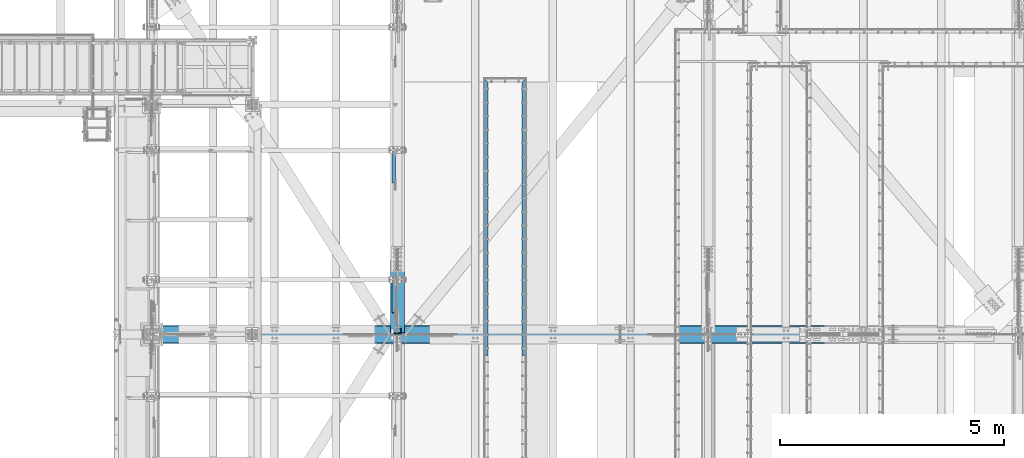
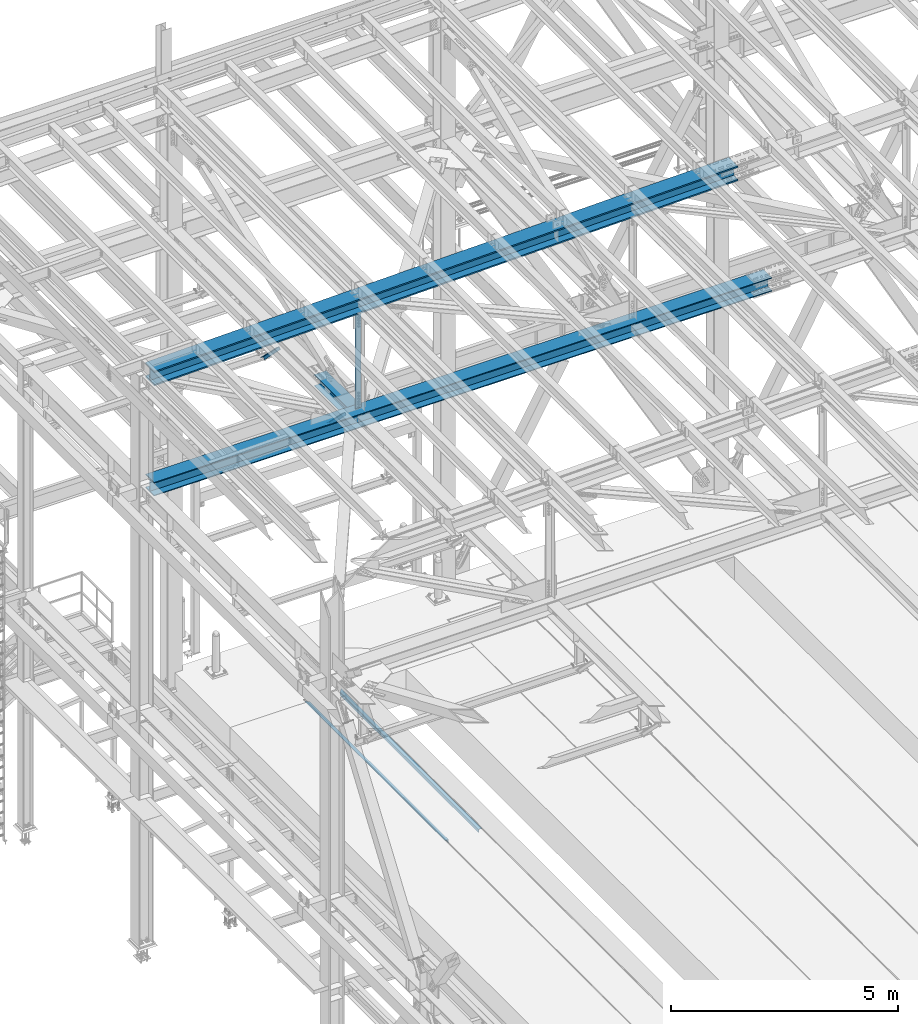
# One storey, part 1880 of 3843: 6 beams, 2 members, 7 elements without a shape of their own.
"""IFC2X3 building model written with IfcOpenShell, lengths in millimetres."""

from ifc_helpers import new_model, si_unit, frame, origin_with_axes, place, context, subcontext, project, spatial, faceted_brep, material, type_object, element, aggregate, save


model = new_model("IFC2X3")

# Units and contexts
model_context = context("Model", 3, precision=1e-05, world=origin_with_axes())
body_context = subcontext(model_context, "Body", "Model", "MODEL_VIEW")
ifc_project = project(units=[si_unit("LENGTHUNIT", "METRE", prefix="MILLI"), si_unit("AREAUNIT", "SQUARE_METRE"), si_unit("VOLUMEUNIT", "CUBIC_METRE"), si_unit("MASSUNIT", "GRAM", prefix="KILO"), si_unit("TIMEUNIT", "SECOND"), si_unit("PLANEANGLEUNIT", "RADIAN"), si_unit("SOLIDANGLEUNIT", "STERADIAN"), si_unit("THERMODYNAMICTEMPERATUREUNIT", "DEGREE_CELSIUS"), si_unit("LUMINOUSINTENSITYUNIT", "LUMEN")], contexts=[model_context])

# Site, building, storey
site_placement = place(None, origin_with_axes())
site = spatial("IfcSite", under=ifc_project, at=site_placement, CompositionType="ELEMENT")
building_placement = place(site_placement, origin_with_axes())
building = spatial("IfcBuilding", under=site, at=building_placement, Name="Undefined", CompositionType="ELEMENT")
storey_placement = place(building_placement, origin_with_axes())
storey = spatial("IfcBuildingStorey", under=building, at=storey_placement, Name="Undefined", CompositionType="ELEMENT", Elevation=0.0)

# Assembly, beam
assembly_1_placement = place(storey_placement, origin_with_axes())
assembly_1 = element("IfcElementAssembly", 1, at=assembly_1_placement, inside=storey, Name="EMBED_ANGLE", AssemblyPlace="NOTDEFINED", PredefinedType="RIGID_FRAME")
ifc_material_1 = material(Name="STEEL/A36")
beam_type_1 = type_object("IfcBeamType", Name="L3-1/2X3-1/2X5/16", PredefinedType="NOTDEFINED")
beam_1_placement = place(assembly_1_placement, frame((44887.896, 89703.275, 30419.675), z_axis=(0.0, 0.0, -1.0), x_axis=(0.0, -1.0, 0.0)))
beam_1 = element("IfcBeam", 2, at=beam_1_placement, type_object=beam_type_1, material=ifc_material_1, Name="EMBED_ANGLE", ObjectType="L3-1/2X3-1/2X5/16", context=body_context, shape_type="Brep", body=[
    faceted_brep([(88.8999999971129, 44.4500000000007, -44.4499999999971), (88.8999999965163, 44.4499999999971, 44.4500000000007), (6184.90000000001, 44.4499999999971, 44.4500000000007), (6184.90000000001, 44.4499999999971, -44.4500000000007), (80.9624999965163, 36.5124999999971, 44.4500000000007), (6184.90000000001, 36.5124999999971, 44.4500000000007), (80.9624999971129, 36.5125000000007, -36.5124999999971), (6184.90000000001, 36.5124999999971, -36.5125000000007), (3.63797880709171e-12, -44.4499999999971, -36.5125000000007), (6184.89999999999, -44.4499999999971, -36.5125000000007), (3.63797880709171e-12, -44.4499999999971, -44.4500000000007), (6184.89999999999, -44.4499999999971, -44.4500000000007)], [[[0, 1, 2, 3]], [[1, 4, 5, 2]], [[4, 6, 7, 5]], [[6, 8, 9, 7]], [[8, 10, 11, 9]], [[10, 0, 3, 11]], [[5, 7, 9, 11, 3, 2]], [[10, 8, 6, 4, 1, 0]]]),
])
aggregate(assembly_1, [beam_1])

assembly_2_placement = place(storey_placement, origin_with_axes())
assembly_2 = element("IfcElementAssembly", 3, at=assembly_2_placement, inside=storey, Name="EMBED_ANGLE", AssemblyPlace="NOTDEFINED", PredefinedType="RIGID_FRAME")
beam_2_placement = place(assembly_2_placement, frame((44036.996, 83518.375, 30419.675), z_axis=(0.0, 0.0, -1.0), x_axis=(0.0, 1.0, 0.0)))
beam_2 = element("IfcBeam", 4, at=beam_2_placement, type_object=beam_type_1, material=ifc_material_1, Name="EMBED_ANGLE", ObjectType="L3-1/2X3-1/2X5/16", context=body_context, shape_type="Brep", body=[
    faceted_brep([(-3.63797880709171e-12, 44.4499999999971, -44.4500000000007), (-3.63797880709171e-12, 44.4499999999971, 44.4500000000007), (6096.0, 44.4499999999971, 44.4500000000007), (6096.0, 44.4499999999971, -44.4500000000007), (-3.63797880709171e-12, 36.5124999999971, 44.4500000000007), (6103.9375, 36.5124999999971, 44.4500000000007), (-3.63797880709171e-12, 36.5124999999971, -36.5125000000007), (6103.9375, 36.5124999999971, -36.5125000000007), (3.63797880709171e-12, -44.4499999999971, -36.5125000000007), (6184.89999999999, -44.4499999999971, -36.5125000000007), (3.63797880709171e-12, -44.4499999999971, -44.4500000000007), (6184.89999999999, -44.4499999999971, -44.4500000000007)], [[[0, 1, 2, 3]], [[1, 4, 5, 2]], [[4, 6, 7, 5]], [[6, 8, 9, 7]], [[8, 10, 11, 9]], [[10, 0, 3, 11]], [[5, 7, 9, 11, 3, 2]], [[10, 8, 6, 4, 1, 0]]]),
])
aggregate(assembly_2, [beam_2])

# Assembly, member
assembly_3_placement = place(storey_placement, origin_with_axes())
assembly_3 = element("IfcElementAssembly", 5, at=assembly_3_placement, inside=storey, Name="ANGLE", AssemblyPlace="NOTDEFINED", PredefinedType="RIGID_FRAME")
ifc_material_2 = material(Name="STEEL/A572-50")
member_type = type_object("IfcMemberType", Name="L3X3X1/4", PredefinedType="NOTDEFINED")
member_1_placement = place(assembly_3_placement, frame((41973.5, 87146.6478294408, 42253.6521705007), z_axis=(0.0, -0.707106781186548, -0.707106781186548), x_axis=(5.70000238222118e-08, 0.707106781186546, -0.707106781186546)))
member_1 = element("IfcMember", 6, at=member_1_placement, type_object=member_type, material=ifc_material_2, Name="ANGLE", ObjectType="L3X3X1/4", context=body_context, shape_type="Brep", body=[
    faceted_brep([(1265.10086725769, -38.0999999999985, -31.7499999999272), (1265.10086725772, -38.0999999999985, -38.0999999999112), (1265.10086725772, 38.0999999999985, -38.0999999999112), (1265.10086725733, 38.0999999999985, 38.099999999904), (1265.10086725733, 31.75, 38.099999999904), (1265.10086725769, 31.75, -31.7499999999272), (274.500867262255, 31.75, 38.0999999999112), (274.500867262619, 31.75, -31.7499999999272), (274.500867262619, -38.0999999999985, -31.7499999999272), (274.500867262648, -38.0999999999985, -38.0999999999112), (274.500867262648, 38.0999999999985, -38.0999999999112), (274.500867262255, 38.0999999999985, 38.0999999999112)], [[[0, 1, 2, 3, 4, 5]], [[5, 4, 6, 7]], [[0, 5, 7, 8]], [[1, 0, 8, 9]], [[2, 1, 9, 10]], [[3, 2, 10, 11]], [[4, 3, 11, 6]], [[10, 9, 8, 7, 6, 11]]]),
])
aggregate(assembly_3, [member_1])

assembly_4_placement = place(storey_placement, origin_with_axes())
assembly_4 = element("IfcElementAssembly", 7, at=assembly_4_placement, inside=storey, Name="ANGLE", AssemblyPlace="NOTDEFINED", PredefinedType="RIGID_FRAME")
member_2_placement = place(assembly_4_placement, frame((41973.5, 84251.0478294408, 42253.6521705007), z_axis=(0.0, -0.707106781186548, -0.707106781186548), x_axis=(5.70000238222118e-08, 0.707106781186546, -0.707106781186546)))
member_2 = element("IfcMember", 8, at=member_2_placement, type_object=member_type, material=ifc_material_2, Name="ANGLE", ObjectType="L3X3X1/4", context=body_context, shape_type="Brep", body=[
    faceted_brep([(1265.10086725769, -38.0999999999985, -31.7499999999272), (1265.10086725772, -38.0999999999985, -38.0999999999112), (1265.10086725772, 38.0999999999985, -38.0999999999112), (1265.10086725733, 38.0999999999985, 38.099999999904), (1265.10086725733, 31.75, 38.099999999904), (1265.10086725769, 31.75, -31.7499999999272), (274.500867262255, 31.75, 38.0999999999112), (274.500867262619, 31.75, -31.7499999999272), (274.500867262619, -38.0999999999985, -31.7499999999272), (274.500867262648, -38.0999999999985, -38.0999999999112), (274.500867262648, 38.0999999999985, -38.0999999999112), (274.500867262255, 38.0999999999985, 38.0999999999112)], [[[0, 1, 2, 3, 4, 5]], [[5, 4, 6, 7]], [[0, 5, 7, 8]], [[1, 0, 8, 9]], [[2, 1, 9, 10]], [[3, 2, 10, 11]], [[4, 3, 11, 6]], [[10, 9, 8, 7, 6, 11]]]),
])
aggregate(assembly_4, [member_2])

# Assembly, beam
assembly_5_placement = place(storey_placement, origin_with_axes())
assembly_5 = element("IfcElementAssembly", 9, at=assembly_5_placement, inside=storey, Name="BEAM", AssemblyPlace="NOTDEFINED", PredefinedType="RIGID_FRAME")
ifc_material_3 = material(Name="STEEL/A992")
beam_type_2 = type_object("IfcBeamType", Name="W12X79", PredefinedType="NOTDEFINED")
beam_3_placement = place(assembly_5_placement, frame((42062.4, 83985.1000001737, 42249.1972440816), z_axis=(0.0, 0.000321673000085866, 0.999999948263239), x_axis=(0.0, 0.999999948263239, -0.000321673000078448)))
beam_3 = element("IfcBeam", 10, at=beam_3_placement, type_object=beam_type_2, material=ifc_material_3, Name="BEAM", ObjectType="W12X79", context=body_context, shape_type="Brep", body=[
    faceted_brep([(19.7931942747964, 6.34999999999854, -131.762499999109), (7.09319427474111, -6.34999999999854, -119.06249999901), (7.09319427478476, -6.34999999999854, 119.06249999904), (19.7931942748546, 6.34999999999854, 131.762499999197), (26.1431942752097, 6.34999999999854, -138.112499999545), (26.1431942752097, 153.987500000003, -138.112499999545), (45.1931942753436, 153.987500000003, -157.162499999431), (45.1931942753436, -153.987500000003, -157.16249999858), (26.1431942752097, -153.987500000003, -138.112499999545), (26.1431942752097, -6.34999999999854, -138.112499999545), (1670.05008663452, -153.987500000003, 138.112500005635), (1670.05008663452, -153.987500000003, 157.162500005586), (45.193194274194, -153.987500000003, 157.162499998878), (26.1431942753406, -153.987500000003, 138.112499999748), (1670.05008663452, 153.987500000003, 157.162500005586), (45.193194274194, 153.987500000003, 157.162499999766), (1670.05008663452, 153.987500000003, 138.112500005635), (26.1431942753406, 153.987500000003, 138.112499999748), (1670.05008663452, 6.34999999999854, 138.112500005635), (26.1431942753406, 6.34999999999854, 138.112499999748), (26.1431942753406, -6.34999999999854, 138.112499999748), (1670.05008663452, -6.34999999999854, 138.112500005635), (1670.05008663452, 6.34999999999854, -138.112499993651), (1670.05008663452, -6.34999999999854, -138.112499993651), (1670.05008663452, -153.987500000003, -138.112499993651), (1670.05008663454, -153.987500000003, -157.162499993603), (1670.05008663454, 153.987500000003, -157.162499993603), (1670.05008663452, 153.987500000003, -138.112499993651)], [[[0, 1, 2, 3]], [[4, 5, 6, 7, 8, 9, 1, 0]], [[10, 11, 12, 13]], [[11, 14, 15, 12]], [[14, 16, 17, 15]], [[16, 18, 19, 17]], [[20, 13, 12, 15, 17, 19, 3, 2]], [[21, 10, 13, 20]], [[22, 18, 16, 14, 11, 10, 21, 23, 24, 25, 26, 27]], [[26, 25, 7, 6]], [[27, 26, 6, 5]], [[22, 27, 5, 4]], [[19, 18, 22, 4, 0, 3]], [[23, 21, 20, 2, 1, 9]], [[24, 23, 9, 8]], [[25, 24, 8, 7]]]),
])

assembly_6_placement = place(storey_placement, origin_with_axes())
assembly_6 = element("IfcElementAssembly", 11, at=assembly_6_placement, inside=storey, Name="BEAM", AssemblyPlace="NOTDEFINED", PredefinedType="RIGID_FRAME")
beam_type_3 = type_object("IfcBeamType", Name="W14X193", PredefinedType="NOTDEFINED")
beam_4_placement = place(assembly_6_placement, frame((36554.8646468845, 83985.1, 45221.0215624366), z_axis=(-0.0216342480057937, 0.0, 0.999765952267441), x_axis=(0.999765952267441, 0.0, 0.0216342480057898)))
beam_4 = element("IfcBeam", 12, at=beam_4_placement, type_object=beam_type_3, material=ifc_material_3, Name="BEAM", ObjectType="W14X193", context=body_context, shape_type="Brep", body=[
    faceted_brep([(213.776684537726, 200.025000000001, -196.85000000026), (214.566790013458, 200.025000000001, -160.337500000169), (15033.9642068568, 200.025000000001, -160.337499981455), (15033.9642068568, 200.025000000001, -196.849999981554), (214.566790013458, 11.1125000000029, -160.337500000169), (15033.9642068568, 11.1125000000029, -160.337499981455), (221.505977235109, 11.1125000000029, 160.337500000714), (15033.9642068568, 11.1125000000029, 160.337500019414), (221.505977235109, 200.025000000001, 160.337500000714), (15033.9642068568, 200.025000000001, 160.337500019414), (222.296082710847, 200.025000000001, 196.850000000813), (15033.9642068568, 200.025000000001, 196.850000019513), (222.296082710847, -200.025000000001, 196.850000000813), (15033.9642068568, -200.025000000001, 196.850000019513), (221.505977235109, -200.025000000001, 160.337500000714), (15033.9642068568, -200.025000000001, 160.337500019414), (221.505977235109, -11.1125000000029, 160.337500000714), (15033.9642068568, -11.1125000000029, 160.337500019414), (214.566790013458, -11.1125000000029, -160.337500000169), (15033.9642068568, -11.1125000000029, -160.337499981455), (214.566790013458, -200.025000000001, -160.337500000169), (15033.9642068568, -200.025000000001, -160.337499981455), (213.776684537726, -200.025000000001, -196.85000000026), (15033.9642068568, -200.025000000001, -196.849999981554)], [[[0, 1, 2, 3]], [[1, 4, 5, 2]], [[4, 6, 7, 5]], [[6, 8, 9, 7]], [[8, 10, 11, 9]], [[10, 12, 13, 11]], [[12, 14, 15, 13]], [[14, 16, 17, 15]], [[16, 18, 19, 17]], [[18, 20, 21, 19]], [[20, 22, 23, 21]], [[22, 0, 3, 23]], [[5, 7, 9, 11, 13, 15, 17, 19, 21, 23, 3, 2]], [[22, 20, 18, 16, 14, 12, 10, 8, 6, 4, 1, 0]]]),
])
aggregate(assembly_6, [beam_4])

# Beam
beam_type_4 = type_object("IfcBeamType", Name="W14X120", PredefinedType="NOTDEFINED")
beam_5_placement = place(assembly_5_placement, frame((36575.9999999129, 83985.1, 42246.5500000005), z_axis=(-0.00048281500021403, 0.0, 0.999999883444831), x_axis=(0.999999883444831, 0.0, 0.000482815000217081)))
beam_5 = element("IfcBeam", 13, at=beam_5_placement, type_object=beam_type_4, material=ifc_material_3, Name="BEAM", ObjectType="W14X120", context=body_context, shape_type="Brep", body=[
    faceted_brep([(196.772609585409, -185.737500000003, -160.337500000758), (196.761112551874, -185.737500000003, -184.150000000795), (15881.3518519562, -185.737500000003, -184.150000040754), (15881.3518519562, -185.737500000003, -160.337500040718), (196.772609585409, -7.14375000000291, -160.337500000758), (15881.3518519562, -7.14375000000291, -160.337500040718), (196.927436303646, -7.14375000000291, 160.337499999754), (15881.3518519562, -7.14375000000291, 160.337499959795), (196.927436303646, -185.737500000003, 160.337499999754), (15881.3518519562, -185.737500000003, 160.337499959795), (196.93893333718, -185.737500000003, 184.14999999979), (15881.3518519562, -185.737500000003, 184.149999959831), (196.93893333718, 185.737500000003, 184.14999999979), (15881.3518519562, 185.737500000003, 184.149999959831), (196.927436303646, 185.737500000003, 160.337499999754), (15881.3518519562, 185.737500000003, 160.337499959795), (196.927436303646, 7.14375000000291, 160.337499999754), (15881.3518519562, 7.14375000000291, 160.337499959795), (196.772609585409, 7.14375000000291, -160.337500000758), (15881.3518519562, 7.14375000000291, -160.337500040718), (196.772609585409, 185.737500000003, -160.337500000758), (15881.3518519562, 185.737500000003, -160.337500040718), (196.761112551874, 185.737500000003, -184.150000000795), (15881.3518519562, 185.737500000003, -184.150000040754)], [[[0, 1, 2, 3]], [[4, 0, 3, 5]], [[6, 4, 5, 7]], [[8, 6, 7, 9]], [[10, 8, 9, 11]], [[12, 10, 11, 13]], [[14, 12, 13, 15]], [[16, 14, 15, 17]], [[18, 16, 17, 19]], [[20, 18, 19, 21]], [[1, 0, 4, 6, 8, 10, 12, 14, 16, 18, 20, 22]], [[1, 22, 23, 2]], [[19, 17, 15, 13, 11, 9, 7, 5, 3, 2, 23, 21]], [[22, 20, 21, 23]]]),
])

aggregate(assembly_5, [beam_3, beam_5])

# Assembly, beam
assembly_7_placement = place(storey_placement, origin_with_axes())
assembly_7 = element("IfcElementAssembly", 14, at=assembly_7_placement, inside=storey, Name="ANGLE", AssemblyPlace="NOTDEFINED", PredefinedType="RIGID_FRAME")
beam_type_5 = type_object("IfcBeamType", Name="L6X6X1/2", PredefinedType="NOTDEFINED")
beam_6_placement = place(assembly_7_placement, frame((42062.4, 84070.8249999998, 45340.2008418066), z_axis=(-1.0, 0.0, 0.0), x_axis=(0.0, 0.0, -1.0)))
beam_6 = element("IfcBeam", 15, at=beam_6_placement, type_object=beam_type_5, material=ifc_material_2, Name="ANGLE", ObjectType="L6X6X1/2", context=body_context, shape_type="Brep", body=[
    faceted_brep([(223.225646543862, 76.1999999999971, -76.1999999999971), (223.225646543862, 76.1999999999971, 76.1999999999971), (2881.50658043286, 76.1999999999971, 76.1999999999971), (2881.50658043286, 76.1999999999971, -76.1999999999971), (223.225646543862, 63.5, 76.1999999999971), (2881.50658043286, 63.5, 76.1999999999971), (223.225646543862, 63.5, -63.5), (2881.50658043286, 63.5, -63.5), (223.225646543862, -76.1999999999971, -63.5), (2881.50658043286, -76.1999999999971, -63.5), (223.225646543862, -76.1999999999971, -76.1999999999971), (2881.50658043286, -76.1999999999971, -76.1999999999971)], [[[0, 1, 2, 3]], [[1, 4, 5, 2]], [[4, 6, 7, 5]], [[6, 8, 9, 7]], [[8, 10, 11, 9]], [[10, 0, 3, 11]], [[5, 7, 9, 11, 3, 2]], [[10, 8, 6, 4, 1, 0]]]),
])
aggregate(assembly_7, [beam_6])

save(model, "model.ifc")
